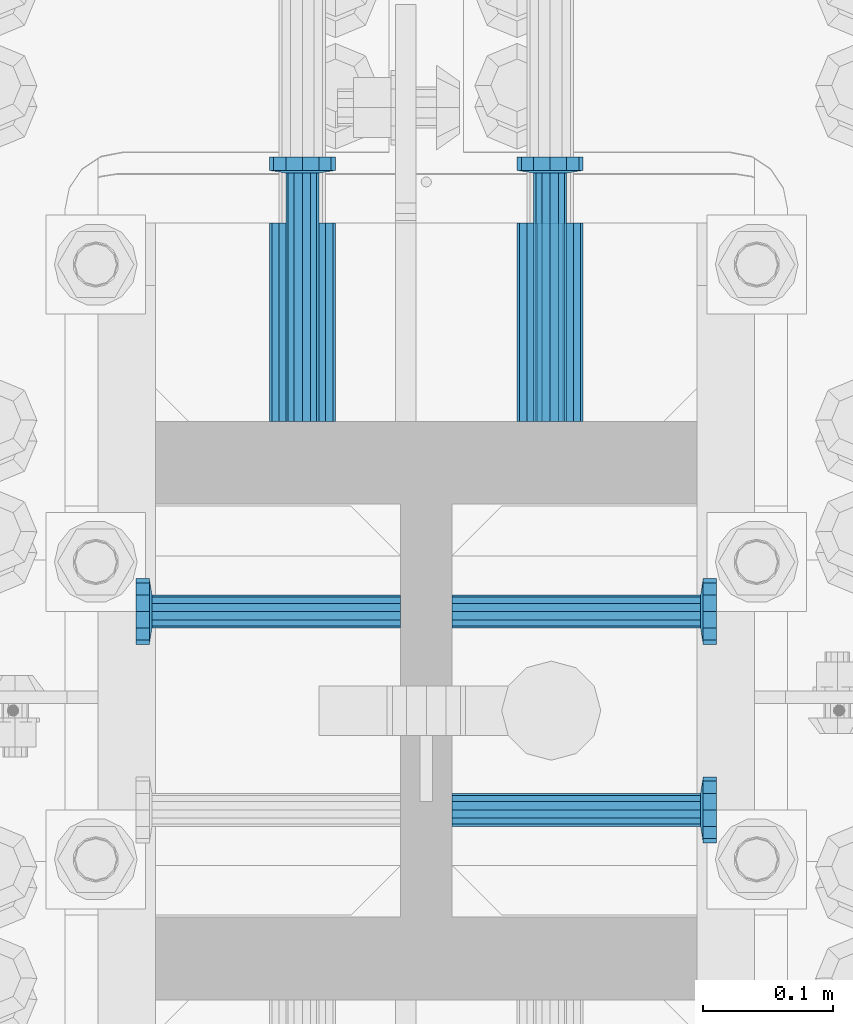
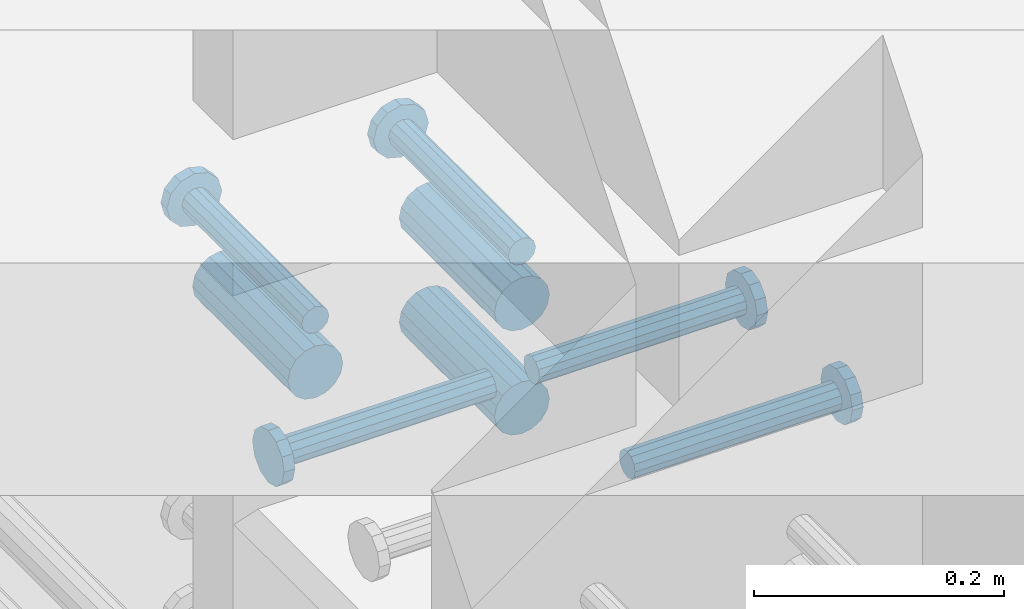
# One storey, part 1304 of 1763: 8 beams, 1 element without a shape of its own.
"""IFC2X3 building model written with IfcOpenShell, lengths in millimetres."""

import ifcopenshell
import ifcopenshell.guid

model = None  # the IFC model being written
_history = None  # IfcOwnerHistory: only IFC2X3 demands one
_inside = {}  # id of a spatial element -> (the spatial element, [elements in it])
_under = {}  # id of a project, library or spatial element -> (it, [spatial elements below it])
_declared = {}  # id of a project -> (the project, [libraries it declares])
_typed = {}  # id of a type object -> (the type object, [elements of that type])
_made_of = {}  # id of a material, layer set ... -> (it, [elements and type objects made of it])


def new_model(schema):
    """Start an empty IFC model of exactly this schema.

    Asked for "IFC4X3", IfcOpenShell would pick the latest addendum, in which some entities
    have other attributes; the version numbers below select the first issue.
    IFC2X3 requires an IfcOwnerHistory on every rooted entity: one is made here for all.
    """
    global model, _history
    if schema == "IFC4X3":
        model = ifcopenshell.file(schema_version=(4, 3, 0, 0))
    else:
        model = ifcopenshell.file(schema=schema)
    _inside.clear()
    _under.clear()
    _declared.clear()
    _typed.clear()
    _made_of.clear()
    _history = None
    if model.schema == "IFC2X3":
        org = make("IfcOrganization", Name="unknown")
        user = make(
            "IfcPersonAndOrganization",
            ThePerson=make("IfcPerson", FamilyName="unknown"),
            TheOrganization=org,
        )
        app = make(
            "IfcApplication",
            ApplicationDeveloper=org,
            Version="unknown",
            ApplicationFullName="unknown",
            ApplicationIdentifier="unknown",
        )
        _history = make(
            "IfcOwnerHistory",
            OwningUser=user,
            OwningApplication=app,
            ChangeAction="ADDED",
            CreationDate=0,
        )
    return model


def make(cls, **values):
    """One entity of the class cls with the attributes given. An attribute that is None is left unset."""
    return model.create_entity(
        cls, **{name: value for name, value in values.items() if value is not None}
    )


def rooted(cls, **values):
    """An entity with a GlobalId (a new one), such as an element, a storey or a relation."""
    return make(cls, GlobalId=ifcopenshell.guid.new(), OwnerHistory=_history, **values)


def si_unit(unit_type, name, prefix=None):
    """IfcSIUnit, for example si_unit("LENGTHUNIT", "METRE", prefix="MILLI")."""
    return make("IfcSIUnit", UnitType=unit_type, Prefix=prefix, Name=name)


def assignment(units):
    """IfcUnitAssignment: the units of a project."""
    return None if units is None else make("IfcUnitAssignment", Units=units)


def point(xyz):
    """IfcCartesianPoint."""
    return None if xyz is None else make("IfcCartesianPoint", Coordinates=xyz)


def direction(xyz):
    """IfcDirection."""
    return None if xyz is None else make("IfcDirection", DirectionRatios=xyz)


def frame(location, z_axis=None, x_axis=None):
    """IfcAxis2Placement3D, a coordinate frame: its origin and axes. An axis left out is left unset."""
    return make(
        "IfcAxis2Placement3D",
        Location=point(location),
        Axis=direction(z_axis),
        RefDirection=direction(x_axis),
    )


def origin_with_axes():
    """The frame at (0, 0, 0) with the z axis (0, 0, 1) and the x axis (1, 0, 0) written out."""
    return frame((0.0, 0.0, 0.0), z_axis=(0.0, 0.0, 1.0), x_axis=(1.0, 0.0, 0.0))


def place(relative_to, where):
    """IfcLocalPlacement: puts the frame where relative to a parent placement (None: the world)."""
    return make(
        "IfcLocalPlacement", PlacementRelTo=relative_to, RelativePlacement=where
    )


def context(
    kind, dimensions, precision=None, world=None, true_north=None, identifier=None
):
    """IfcGeometricRepresentationContext, for example the 3D "Model" context."""
    return make(
        "IfcGeometricRepresentationContext",
        ContextIdentifier=identifier,
        ContextType=kind,
        CoordinateSpaceDimension=dimensions,
        Precision=precision,
        WorldCoordinateSystem=world,
        TrueNorth=true_north,
    )


def subcontext(parent, identifier, kind, view, scale=None):
    """IfcGeometricRepresentationSubContext, for example "Body" below "Model"."""
    return make(
        "IfcGeometricRepresentationSubContext",
        ContextIdentifier=identifier,
        ContextType=kind,
        ParentContext=parent,
        TargetScale=scale,
        TargetView=view,
    )


def project(units=None, contexts=None):
    """IfcProject with its units and contexts."""
    return rooted(
        "IfcProject",
        Name="project",
        RepresentationContexts=contexts,
        UnitsInContext=assignment(units),
    )


def spatial(cls, under=None, at=None, **own):
    """A site, building, storey or space (cls), placed at a placement, below another one or the project."""
    s = rooted(cls, ObjectPlacement=at, **own)
    if under is not None:
        _under.setdefault(under.id(), (under, []))[1].append(s)
    return s


def faces_of(points, faces, orient=None, outer=None):
    """IfcFace entities. A face is a list of loops; a loop is a list of indices into points, from 0.

    orient and outer hold one flag for each loop. By default every Orientation is true, the
    first loop of a face is its IfcFaceOuterBound and the others are IfcFaceBound.
    """
    made = []
    for i, loops in enumerate(faces):
        bounds = []
        for j, loop in enumerate(loops):
            is_outer = j == 0 if outer is None else outer[i][j]
            bounds.append(
                make(
                    "IfcFaceOuterBound" if is_outer else "IfcFaceBound",
                    Bound=make("IfcPolyLoop", Polygon=[points[k] for k in loop]),
                    Orientation=True if orient is None else orient[i][j],
                )
            )
        made.append(make("IfcFace", Bounds=bounds))
    return made


def faceted_brep(points, faces, orient=None, outer=None, voids=None):
    """IfcFacetedBrep: a solid bounded by flat faces; with voids (closed shells), ...WithVoids."""
    shared = [point(p) for p in points]
    hull = make("IfcClosedShell", CfsFaces=faces_of(shared, faces, orient, outer))
    if voids is None:
        return make("IfcFacetedBrep", Outer=hull)
    return make(
        "IfcFacetedBrepWithVoids",
        Outer=hull,
        Voids=[
            make(cls, CfsFaces=faces_of(shared, fs, o, b)) for cls, fs, o, b in voids
        ],
    )


def shape(context_of_items, identifier, shape_type, items):
    """IfcShapeRepresentation: the items that make up one representation, for example the "Body"."""
    return make(
        "IfcShapeRepresentation",
        ContextOfItems=context_of_items,
        RepresentationIdentifier=identifier,
        RepresentationType=shape_type,
        Items=items,
    )


def material(Name=None, Category=None):
    """IfcMaterial."""
    return make("IfcMaterial", Name=Name, Category=Category)


def made_of(thing, what):
    """Note that an element or type object is made of a material, layer set ...; save() writes the relation."""
    if what is not None:
        _made_of.setdefault(what.id(), (what, []))[1].append(thing)
    return thing


def type_object(cls, material=None, **own):
    """A type object (cls), such as IfcWallType, which elements share."""
    return made_of(rooted(cls, **own), material)


def element(
    cls,
    number,
    at=None,
    inside=None,
    cuts=None,
    type_object=None,
    material=None,
    context=None,
    identifier="Body",
    shape_type=None,
    held_by="IfcProductDefinitionShape",
    body=None,
    shapes=None,
    **own,
):
    """One element of the class cls, such as IfcWall. Its Tag is "e" and its number.

    at: its placement. inside: the storey or other place that contains it. cuts: it is an
    opening in that element (IfcRelVoidsElement). A single representation is given by context,
    identifier, shape_type and body (its items); several are given by shapes. held_by: the class
    of the entity that holds the representations. save() writes the other relations.
    """
    e = rooted(cls, Tag="e%d" % number, ObjectPlacement=at, **own)
    if body is not None:
        shapes = [shape(context, identifier, shape_type, body)]
    if shapes is not None:
        e.Representation = make(held_by, Representations=shapes)
    if inside is not None:
        _inside.setdefault(inside.id(), (inside, []))[1].append(e)
    if cuts is not None:
        rooted(
            "IfcRelVoidsElement", RelatingBuildingElement=cuts, RelatedOpeningElement=e
        )
    if type_object is not None:
        _typed.setdefault(type_object.id(), (type_object, []))[1].append(e)
    return made_of(e, material)


def aggregate(whole, parts):
    """IfcRelAggregates: a whole, such as a stair, and the parts it consists of."""
    return rooted("IfcRelAggregates", RelatingObject=whole, RelatedObjects=parts)


def save(model, path):
    """Write the relations noted so far, then the file.

    IfcRelAggregates (storeys below a building ...), IfcRelContainedInSpatialStructure (elements
    in a storey), IfcRelDefinesByType, IfcRelAssociatesMaterial and IfcRelDeclares: one each for
    every whole, place, type object, material and project.
    """
    for whole, parts in _under.values():
        aggregate(whole, parts)
    for where, things in _inside.values():
        rooted(
            "IfcRelContainedInSpatialStructure",
            RelatedElements=things,
            RelatingStructure=where,
        )
    for kind, things in _typed.values():
        rooted("IfcRelDefinesByType", RelatedObjects=things, RelatingType=kind)
    for what, things in _made_of.values():
        rooted("IfcRelAssociatesMaterial", RelatedObjects=things, RelatingMaterial=what)
    for by, libraries in _declared.values():
        rooted("IfcRelDeclares", RelatingContext=by, RelatedDefinitions=libraries)
    model.write(path)


model = new_model("IFC2X3")

# Units and contexts
model_context = context("Model", 3, precision=1e-05, world=origin_with_axes())
body_context = subcontext(model_context, "Body", "Model", "MODEL_VIEW")
ifc_project = project(units=[si_unit("LENGTHUNIT", "METRE", prefix="MILLI"), si_unit("AREAUNIT", "SQUARE_METRE"), si_unit("VOLUMEUNIT", "CUBIC_METRE"), si_unit("MASSUNIT", "GRAM", prefix="KILO"), si_unit("TIMEUNIT", "SECOND"), si_unit("PLANEANGLEUNIT", "RADIAN"), si_unit("SOLIDANGLEUNIT", "STERADIAN"), si_unit("THERMODYNAMICTEMPERATUREUNIT", "DEGREE_CELSIUS"), si_unit("LUMINOUSINTENSITYUNIT", "LUMEN")], contexts=[model_context])

# Site, building, storey
site_placement = place(None, origin_with_axes())
site = spatial("IfcSite", under=ifc_project, at=site_placement, CompositionType="ELEMENT")
building_placement = place(site_placement, origin_with_axes())
building = spatial("IfcBuilding", under=site, at=building_placement, Name="Undefined", CompositionType="ELEMENT")
storey_placement = place(building_placement, origin_with_axes())
storey = spatial("IfcBuildingStorey", under=building, at=storey_placement, Name="Undefined", CompositionType="ELEMENT", Elevation=0.0)

# Assembly, beams
assembly_placement = place(storey_placement, origin_with_axes())
assembly = element("IfcElementAssembly", 1, at=assembly_placement, inside=storey, Name="COLUMN", AssemblyPlace="NOTDEFINED", PredefinedType="RIGID_FRAME")
ifc_material_1 = material(Name="STEEL/A706-GR.80")
beam_type_1 = type_object("IfcBeamType", PredefinedType="NOTDEFINED")
beam_1_placement = place(assembly_placement, frame((-23932.5872736985, 679.449862528949, 4775.20000000009), z_axis=(0.0, 0.0, 1.0), x_axis=(0.0, 1.0, 0.0)))
beam_1 = element("IfcBeam", 2, at=beam_1_placement, type_object=beam_type_1, material=ifc_material_1, Name="HALF COUPLER F", context=body_context, shape_type="Brep", body=[
    faceted_brep([(32.7659999999996, -8.95349999999962, -15.507916905568), (32.7659999999996, 0.0, -17.9070000000002), (32.7659999999996, 8.95349999999962, -15.507916905568), (32.7659999999996, 15.507916905568, -8.95350000000008), (32.7659999999996, 17.9069999999992, 0.0), (32.7659999999996, 15.507916905568, 8.95350000000008), (32.7659999999996, 8.95349999999962, 15.507916905568), (32.7659999999996, 0.0, 17.9070000000002), (32.7659999999996, -8.95349999999962, 15.507916905568), (32.7659999999996, -15.507916905568, 8.95350000000008), (32.7659999999996, -17.9069999999992, 0.0), (32.7659999999996, -15.507916905568, -8.95350000000008), (152.400103102711, -15.507916905568, 8.95350000000008), (152.400103102711, -8.95349999999962, 15.507916905568), (152.400103102711, -17.9069999999992, 0.0), (152.400103102711, -15.507916905568, -8.95350000000008), (152.400103102711, -8.95349999999962, -15.507916905568), (152.400103102711, 0.0, -17.9070000000002), (152.400103102711, 8.95349999999962, -15.507916905568), (152.400103102711, 15.507916905568, -8.95350000000008), (152.400103102711, 17.9069999999992, 0.0), (152.400103102711, 15.507916905568, 8.95350000000008), (152.400103102711, 8.95349999999962, 15.507916905568), (152.400103102711, 0.0, 17.9070000000002), (0.0, -23.466540125788, 9.72015918207308), (0.0, -17.9605122421381, 17.9605122421385), (0.0, -9.72015918207398, 23.4665401257867), (0.0, 0.0, 25.4000000000001), (0.0, 9.72015918207398, 23.4665401257867), (0.0, 17.9605122421381, 17.9605122421385), (0.0, 23.466540125788, 9.72015918207308), (0.0, 25.4000000000015, 0.0), (0.0, 23.466540125788, -9.72015918207308), (0.0, 17.9605122421381, -17.9605122421385), (0.0, 9.72015918207398, -23.4665401257867), (0.0, 0.0, -25.4000000000001), (0.0, -9.72015918207398, -23.4665401257867), (0.0, -17.9605122421381, -17.9605122421385), (0.0, -23.466540125788, -9.72015918207308), (0.0, -25.4000000000015, 0.0), (152.400103102711, -25.4000000000015, 0.0), (152.400103102711, -23.466540125788, 9.72015918207308), (152.400103102711, -17.9605122421381, 17.9605122421385), (152.400103102711, -9.72015918207398, 23.4665401257867), (152.400103102711, 0.0, 25.4000000000001), (152.400103102711, 9.72015918207398, 23.4665401257867), (152.400103102711, 17.9605122421381, 17.9605122421385), (152.400103102711, 23.466540125788, 9.72015918207308), (152.400103102711, 25.4000000000015, 0.0), (152.400103102711, 23.466540125788, -9.72015918207308), (152.400103102711, 17.9605122421381, -17.9605122421385), (152.400103102711, 9.72015918207398, -23.4665401257867), (152.400103102711, 0.0, -25.4000000000001), (152.400103102711, -9.72015918207398, -23.4665401257867), (152.400103102711, -17.9605122421381, -17.9605122421385), (152.400103102711, -23.466540125788, -9.72015918207308)], [[[0, 1, 2, 3, 4, 5, 6, 7, 8, 9, 10, 11]], [[12, 9, 8, 13]], [[14, 10, 9, 12]], [[15, 11, 10, 14]], [[16, 0, 11, 15]], [[17, 1, 0, 16]], [[18, 2, 1, 17]], [[19, 3, 2, 18]], [[20, 4, 3, 19]], [[21, 5, 4, 20]], [[22, 6, 5, 21]], [[23, 7, 6, 22]], [[13, 8, 7, 23]], [[24, 25, 26, 27, 28, 29, 30, 31, 32, 33, 34, 35, 36, 37, 38, 39]], [[24, 39, 40, 41]], [[25, 24, 41, 42]], [[26, 25, 42, 43]], [[27, 26, 43, 44]], [[28, 27, 44, 45]], [[29, 28, 45, 46]], [[30, 29, 46, 47]], [[31, 30, 47, 48]], [[32, 31, 48, 49]], [[33, 32, 49, 50]], [[34, 33, 50, 51]], [[35, 34, 51, 52]], [[36, 35, 52, 53]], [[37, 36, 53, 54]], [[38, 37, 54, 55]], [[39, 38, 55, 40]], [[54, 53, 52, 51, 50, 49, 48, 47, 46, 45, 44, 43, 42, 41, 40, 55], [21, 20, 19, 18, 17, 16, 15, 14, 12, 13, 23, 22]]]),
])
beam_2_placement = place(assembly_placement, frame((-24123.0872736984, 679.450068735522, 4876.80000000009), z_axis=(0.0, 0.0, 1.0), x_axis=(0.0, 1.0, 0.0)))
beam_2 = element("IfcBeam", 3, at=beam_2_placement, type_object=beam_type_1, material=ifc_material_1, Name="HALF COUPLER F", context=body_context, shape_type="Brep", body=[
    faceted_brep([(32.7659999999996, -8.95349999999962, -15.507916905568), (32.7659999999996, 0.0, -17.9070000000002), (32.7659999999996, 8.95349999999962, -15.507916905568), (32.7659999999996, 15.507916905568, -8.95350000000008), (32.7659999999996, 17.9069999999992, 0.0), (32.7659999999996, 15.507916905568, 8.95350000000008), (32.7659999999996, 8.95349999999962, 15.507916905568), (32.7659999999996, 0.0, 17.9070000000002), (32.7659999999996, -8.95349999999962, 15.507916905568), (32.7659999999996, -15.507916905568, 8.95350000000008), (32.7659999999996, -17.9069999999992, 0.0), (32.7659999999996, -15.507916905568, -8.95350000000008), (152.400103102711, -15.507916905568, 8.95350000000008), (152.400103102711, -8.95349999999962, 15.507916905568), (152.400103102711, -17.9069999999992, 0.0), (152.400103102711, -15.507916905568, -8.95350000000008), (152.400103102711, -8.95349999999962, -15.507916905568), (152.400103102711, 0.0, -17.9070000000002), (152.400103102711, 8.95349999999962, -15.507916905568), (152.400103102711, 15.507916905568, -8.95350000000008), (152.400103102711, 17.9069999999992, 0.0), (152.400103102711, 15.507916905568, 8.95350000000008), (152.400103102711, 8.95349999999962, 15.507916905568), (152.400103102711, 0.0, 17.9070000000002), (0.0, -23.466540125788, 9.72015918207308), (0.0, -17.9605122421381, 17.9605122421385), (0.0, -9.72015918207398, 23.4665401257867), (0.0, 0.0, 25.4000000000001), (0.0, 9.72015918207398, 23.4665401257867), (0.0, 17.9605122421381, 17.9605122421385), (0.0, 23.466540125788, 9.72015918207308), (0.0, 25.4000000000015, 0.0), (0.0, 23.466540125788, -9.72015918207308), (0.0, 17.9605122421381, -17.9605122421385), (0.0, 9.72015918207398, -23.4665401257867), (0.0, 0.0, -25.4000000000001), (0.0, -9.72015918207398, -23.4665401257867), (0.0, -17.9605122421381, -17.9605122421385), (0.0, -23.466540125788, -9.72015918207308), (0.0, -25.4000000000015, 0.0), (152.400103102711, -25.4000000000015, 0.0), (152.400103102711, -23.466540125788, 9.72015918207308), (152.400103102711, -17.9605122421381, 17.9605122421385), (152.400103102711, -9.72015918207398, 23.4665401257867), (152.400103102711, 0.0, 25.4000000000001), (152.400103102711, 9.72015918207398, 23.4665401257867), (152.400103102711, 17.9605122421381, 17.9605122421385), (152.400103102711, 23.466540125788, 9.72015918207308), (152.400103102711, 25.4000000000015, 0.0), (152.400103102711, 23.466540125788, -9.72015918207308), (152.400103102711, 17.9605122421381, -17.9605122421385), (152.400103102711, 9.72015918207398, -23.4665401257867), (152.400103102711, 0.0, -25.4000000000001), (152.400103102711, -9.72015918207398, -23.4665401257867), (152.400103102711, -17.9605122421381, -17.9605122421385), (152.400103102711, -23.466540125788, -9.72015918207308)], [[[0, 1, 2, 3, 4, 5, 6, 7, 8, 9, 10, 11]], [[12, 9, 8, 13]], [[14, 10, 9, 12]], [[15, 11, 10, 14]], [[16, 0, 11, 15]], [[17, 1, 0, 16]], [[18, 2, 1, 17]], [[19, 3, 2, 18]], [[20, 4, 3, 19]], [[21, 5, 4, 20]], [[22, 6, 5, 21]], [[23, 7, 6, 22]], [[13, 8, 7, 23]], [[24, 25, 26, 27, 28, 29, 30, 31, 32, 33, 34, 35, 36, 37, 38, 39]], [[24, 39, 40, 41]], [[25, 24, 41, 42]], [[26, 25, 42, 43]], [[27, 26, 43, 44]], [[28, 27, 44, 45]], [[29, 28, 45, 46]], [[30, 29, 46, 47]], [[31, 30, 47, 48]], [[32, 31, 48, 49]], [[33, 32, 49, 50]], [[34, 33, 50, 51]], [[35, 34, 51, 52]], [[36, 35, 52, 53]], [[37, 36, 53, 54]], [[38, 37, 54, 55]], [[39, 38, 55, 40]], [[54, 53, 52, 51, 50, 49, 48, 47, 46, 45, 44, 43, 42, 41, 40, 55], [21, 20, 19, 18, 17, 16, 15, 14, 12, 13, 23, 22]]]),
])
beam_3_placement = place(assembly_placement, frame((-23932.5872736985, 679.449999999998, 4876.80000000009), z_axis=(0.0, 0.0, 1.0), x_axis=(0.0, 1.0, 0.0)))
beam_3 = element("IfcBeam", 4, at=beam_3_placement, type_object=beam_type_1, material=ifc_material_1, Name="HALF COUPLER F", context=body_context, shape_type="Brep", body=[
    faceted_brep([(32.7659999999996, -8.95349999999962, -15.507916905568), (32.7659999999996, 0.0, -17.9070000000002), (32.7659999999996, 8.95349999999962, -15.507916905568), (32.7659999999996, 15.507916905568, -8.95350000000008), (32.7659999999996, 17.9069999999992, 0.0), (32.7659999999996, 15.507916905568, 8.95350000000008), (32.7659999999996, 8.95349999999962, 15.507916905568), (32.7659999999996, 0.0, 17.9070000000002), (32.7659999999996, -8.95349999999962, 15.507916905568), (32.7659999999996, -15.507916905568, 8.95350000000008), (32.7659999999996, -17.9069999999992, 0.0), (32.7659999999996, -15.507916905568, -8.95350000000008), (152.400103102711, -15.507916905568, 8.95350000000008), (152.400103102711, -8.95349999999962, 15.507916905568), (152.400103102711, -17.9069999999992, 0.0), (152.400103102711, -15.507916905568, -8.95350000000008), (152.400103102711, -8.95349999999962, -15.507916905568), (152.400103102711, 0.0, -17.9070000000002), (152.400103102711, 8.95349999999962, -15.507916905568), (152.400103102711, 15.507916905568, -8.95350000000008), (152.400103102711, 17.9069999999992, 0.0), (152.400103102711, 15.507916905568, 8.95350000000008), (152.400103102711, 8.95349999999962, 15.507916905568), (152.400103102711, 0.0, 17.9070000000002), (0.0, -23.466540125788, 9.72015918207308), (0.0, -17.9605122421381, 17.9605122421385), (0.0, -9.72015918207398, 23.4665401257867), (0.0, 0.0, 25.4000000000001), (0.0, 9.72015918207398, 23.4665401257867), (0.0, 17.9605122421381, 17.9605122421385), (0.0, 23.466540125788, 9.72015918207308), (0.0, 25.4000000000015, 0.0), (0.0, 23.466540125788, -9.72015918207308), (0.0, 17.9605122421381, -17.9605122421385), (0.0, 9.72015918207398, -23.4665401257867), (0.0, 0.0, -25.4000000000001), (0.0, -9.72015918207398, -23.4665401257867), (0.0, -17.9605122421381, -17.9605122421385), (0.0, -23.466540125788, -9.72015918207308), (0.0, -25.4000000000015, 0.0), (152.400103102711, -25.4000000000015, 0.0), (152.400103102711, -23.466540125788, 9.72015918207308), (152.400103102711, -17.9605122421381, 17.9605122421385), (152.400103102711, -9.72015918207398, 23.4665401257867), (152.400103102711, 0.0, 25.4000000000001), (152.400103102711, 9.72015918207398, 23.4665401257867), (152.400103102711, 17.9605122421381, 17.9605122421385), (152.400103102711, 23.466540125788, 9.72015918207308), (152.400103102711, 25.4000000000015, 0.0), (152.400103102711, 23.466540125788, -9.72015918207308), (152.400103102711, 17.9605122421381, -17.9605122421385), (152.400103102711, 9.72015918207398, -23.4665401257867), (152.400103102711, 0.0, -25.4000000000001), (152.400103102711, -9.72015918207398, -23.4665401257867), (152.400103102711, -17.9605122421381, -17.9605122421385), (152.400103102711, -23.466540125788, -9.72015918207308)], [[[0, 1, 2, 3, 4, 5, 6, 7, 8, 9, 10, 11]], [[12, 9, 8, 13]], [[14, 10, 9, 12]], [[15, 11, 10, 14]], [[16, 0, 11, 15]], [[17, 1, 0, 16]], [[18, 2, 1, 17]], [[19, 3, 2, 18]], [[20, 4, 3, 19]], [[21, 5, 4, 20]], [[22, 6, 5, 21]], [[23, 7, 6, 22]], [[13, 8, 7, 23]], [[24, 25, 26, 27, 28, 29, 30, 31, 32, 33, 34, 35, 36, 37, 38, 39]], [[24, 39, 40, 41]], [[25, 24, 41, 42]], [[26, 25, 42, 43]], [[27, 26, 43, 44]], [[28, 27, 44, 45]], [[29, 28, 45, 46]], [[30, 29, 46, 47]], [[31, 30, 47, 48]], [[32, 31, 48, 49]], [[33, 32, 49, 50]], [[34, 33, 50, 51]], [[35, 34, 51, 52]], [[36, 35, 52, 53]], [[37, 36, 53, 54]], [[38, 37, 54, 55]], [[39, 38, 55, 40]], [[54, 53, 52, 51, 50, 49, 48, 47, 46, 45, 44, 43, 42, 41, 40, 55], [21, 20, 19, 18, 17, 16, 15, 14, 12, 13, 23, 22]]]),
])
ifc_material_2 = material(Name="STEEL/A108")
beam_type_2 = type_object("IfcBeamType", PredefinedType="NOTDEFINED")
beam_4_placement = place(assembly_placement, frame((-24007.9935227012, 381.000138137178, 4927.60000000008), z_axis=(0.0, -1.0, 0.0), x_axis=(1.0, 0.0, 0.0)))
beam_4 = element("IfcBeam", 5, at=beam_4_placement, type_object=beam_type_2, material=ifc_material_2, Name="HEADED STUD ANCHOR", context=body_context, shape_type="Brep", body=[
    faceted_brep([(0.0, -12.6999999999971, -1.81898940354586e-12), (3.63797880709171e-12, -11.0, -6.34999990463257), (191.00799999576, -11.0, -6.34999990454889), (191.007999995752, -12.6999998092651, 8.36735125631094e-11), (7.27595761418343e-12, -6.34999990463257, -11.0), (191.00799999576, -6.34999990463257, -10.9999999999163), (3.63797880709171e-12, 0.0, -12.6999998092651), (191.00799999576, 0.0, -12.6999998091815), (7.27595761418343e-12, 6.34999990463257, -11.0), (191.00799999576, 6.34999990463257, -10.9999999999163), (3.63797880709171e-12, 11.0, -6.34999990463257), (191.00799999576, 11.0, -6.34999990454889), (0.0, 12.6999999999971, -1.81898940354586e-12), (191.007999995752, 12.6999998092651, 8.36735125631094e-11), (0.0, 11.0, 6.34999990463257), (191.007999995752, 11.0, 6.34999990471624), (-3.63797880709171e-12, 6.34999990463257, 11.0), (191.007999995749, 6.34999990463257, 11.0000000000837), (-3.63797880709171e-12, 0.0, 12.6999998092651), (191.007999995749, 0.0, 12.6999998093488), (-3.63797880709171e-12, -6.34999990463257, 11.0), (191.007999995749, -6.34999990463257, 11.0000000000837), (0.0, -11.0, 6.34999990463257), (191.007999995752, -11.0, 6.34999990471624), (193.039999995715, -22.0, -12.6999998091796), (193.039999995708, -25.3999996185303, 8.54925019666553e-11), (193.039999995719, -12.6999998092651, -21.9999999999145), (193.039999995719, 0.0, -25.3999996184448), (193.039999995719, 12.6999998092651, -21.9999999999145), (193.039999995715, 22.0, -12.6999998091796), (193.039999995708, 25.3999996185303, 8.54925019666553e-11), (193.039999995704, 22.0, 12.6999998093506), (193.039999995701, 12.6999998092651, 22.0000000000855), (193.039999995697, 0.0, 25.3999996186158), (193.039999995701, -12.6999998092651, 22.0000000000855), (193.039999995704, -22.0, 12.6999998093506), (203.199999995486, -22.0, -12.6999998091742), (203.199999995482, -25.3999996185303, 9.09494701772928e-11), (203.199999995493, -12.6999998092651, -21.9999999999091), (203.199999995493, 0.0, -25.3999996184393), (203.199999995493, 12.6999998092651, -21.9999999999091), (203.199999995486, 22.0, -12.6999998091742), (203.199999995482, 25.3999996185303, 9.09494701772928e-11), (203.199999995479, 22.0, 12.6999998093561), (203.199999995475, 12.6999998092651, 22.0000000000909), (203.199999995471, 0.0, 25.3999996186212), (203.199999995475, -12.6999998092651, 22.0000000000909), (203.199999995479, -22.0, 12.6999998093561)], [[[0, 1, 2, 3]], [[1, 4, 5, 2]], [[4, 6, 7, 5]], [[6, 8, 9, 7]], [[8, 10, 11, 9]], [[10, 12, 13, 11]], [[12, 14, 15, 13]], [[14, 16, 17, 15]], [[16, 18, 19, 17]], [[18, 20, 21, 19]], [[20, 22, 23, 21]], [[22, 0, 3, 23]], [[22, 20, 18, 16, 14, 12, 10, 8, 6, 4, 1, 0]], [[3, 2, 24, 25]], [[2, 5, 26, 24]], [[5, 7, 27, 26]], [[7, 9, 28, 27]], [[9, 11, 29, 28]], [[11, 13, 30, 29]], [[13, 15, 31, 30]], [[15, 17, 32, 31]], [[17, 19, 33, 32]], [[19, 21, 34, 33]], [[21, 23, 35, 34]], [[23, 3, 25, 35]], [[25, 24, 36, 37]], [[24, 26, 38, 36]], [[26, 27, 39, 38]], [[27, 28, 40, 39]], [[28, 29, 41, 40]], [[29, 30, 42, 41]], [[30, 31, 43, 42]], [[31, 32, 44, 43]], [[32, 33, 45, 44]], [[33, 34, 46, 45]], [[34, 35, 47, 46]], [[35, 25, 37, 47]], [[38, 39, 40, 41, 42, 43, 44, 45, 46, 47, 37, 36]]]),
])
beam_5_placement = place(assembly_placement, frame((-24007.9935236984, 533.400138136968, 4927.60000000008), z_axis=(0.0, -1.0, 0.0), x_axis=(1.0, 0.0, 0.0)))
beam_5 = element("IfcBeam", 6, at=beam_5_placement, type_object=beam_type_2, material=ifc_material_2, Name="HEADED STUD ANCHOR", context=body_context, shape_type="Brep", body=[
    faceted_brep([(0.0, -12.6999999999971, -1.81898940354586e-12), (3.63797880709171e-12, -11.0, -6.34999990463257), (191.00799999576, -11.0, -6.34999990454889), (191.007999995752, -12.6999998092651, 8.36735125631094e-11), (7.27595761418343e-12, -6.34999990463257, -11.0), (191.00799999576, -6.34999990463257, -10.9999999999163), (3.63797880709171e-12, 0.0, -12.6999998092651), (191.00799999576, 0.0, -12.6999998091815), (7.27595761418343e-12, 6.34999990463257, -11.0), (191.00799999576, 6.34999990463257, -10.9999999999163), (3.63797880709171e-12, 11.0, -6.34999990463257), (191.00799999576, 11.0, -6.34999990454889), (0.0, 12.6999999999971, -1.81898940354586e-12), (191.007999995752, 12.6999998092651, 8.36735125631094e-11), (0.0, 11.0, 6.34999990463257), (191.007999995752, 11.0, 6.34999990471624), (-3.63797880709171e-12, 6.34999990463257, 11.0), (191.007999995749, 6.34999990463257, 11.0000000000837), (-3.63797880709171e-12, 0.0, 12.6999998092651), (191.007999995749, 0.0, 12.6999998093488), (-3.63797880709171e-12, -6.34999990463257, 11.0), (191.007999995749, -6.34999990463257, 11.0000000000837), (0.0, -11.0, 6.34999990463257), (191.007999995752, -11.0, 6.34999990471624), (193.039999995715, -22.0, -12.6999998091796), (193.039999995708, -25.3999996185303, 8.54925019666553e-11), (193.039999995719, -12.6999998092651, -21.9999999999145), (193.039999995719, 0.0, -25.3999996184448), (193.039999995719, 12.6999998092651, -21.9999999999145), (193.039999995715, 22.0, -12.6999998091796), (193.039999995708, 25.3999996185303, 8.54925019666553e-11), (193.039999995704, 22.0, 12.6999998093506), (193.039999995701, 12.6999998092651, 22.0000000000855), (193.039999995697, 0.0, 25.3999996186158), (193.039999995701, -12.6999998092651, 22.0000000000855), (193.039999995704, -22.0, 12.6999998093506), (203.199999995486, -22.0, -12.6999998091742), (203.199999995482, -25.3999996185303, 9.09494701772928e-11), (203.199999995493, -12.6999998092651, -21.9999999999091), (203.199999995493, 0.0, -25.3999996184393), (203.199999995493, 12.6999998092651, -21.9999999999091), (203.199999995486, 22.0, -12.6999998091742), (203.199999995482, 25.3999996185303, 9.09494701772928e-11), (203.199999995479, 22.0, 12.6999998093561), (203.199999995475, 12.6999998092651, 22.0000000000909), (203.199999995471, 0.0, 25.3999996186212), (203.199999995475, -12.6999998092651, 22.0000000000909), (203.199999995479, -22.0, 12.6999998093561)], [[[0, 1, 2, 3]], [[1, 4, 5, 2]], [[4, 6, 7, 5]], [[6, 8, 9, 7]], [[8, 10, 11, 9]], [[10, 12, 13, 11]], [[12, 14, 15, 13]], [[14, 16, 17, 15]], [[16, 18, 19, 17]], [[18, 20, 21, 19]], [[20, 22, 23, 21]], [[22, 0, 3, 23]], [[22, 20, 18, 16, 14, 12, 10, 8, 6, 4, 1, 0]], [[3, 2, 24, 25]], [[2, 5, 26, 24]], [[5, 7, 27, 26]], [[7, 9, 28, 27]], [[9, 11, 29, 28]], [[11, 13, 30, 29]], [[13, 15, 31, 30]], [[15, 17, 32, 31]], [[17, 19, 33, 32]], [[19, 21, 34, 33]], [[21, 23, 35, 34]], [[23, 3, 25, 35]], [[25, 24, 36, 37]], [[24, 26, 38, 36]], [[26, 27, 39, 38]], [[27, 28, 40, 39]], [[28, 29, 41, 40]], [[29, 30, 42, 41]], [[30, 31, 43, 42]], [[31, 32, 44, 43]], [[32, 33, 45, 44]], [[33, 34, 46, 45]], [[34, 35, 47, 46]], [[35, 25, 37, 47]], [[38, 39, 40, 41, 42, 43, 44, 45, 46, 47, 37, 36]]]),
])
beam_6_placement = place(assembly_placement, frame((-23932.5872736985, 679.450068734938, 4927.60000000008), z_axis=(1.0, 0.0, 0.0), x_axis=(0.0, 1.0, 0.0)))
beam_6 = element("IfcBeam", 7, at=beam_6_placement, type_object=beam_type_2, material=ifc_material_2, Name="HEADED STUD ANCHOR", context=body_context, shape_type="Brep", body=[
    faceted_brep([(0.0, -12.6999999999971, -1.81898940354586e-12), (3.63797880709171e-12, -11.0, -6.34999990463257), (191.00799999576, -11.0, -6.34999990454889), (191.007999995752, -12.6999998092651, 8.36735125631094e-11), (7.27595761418343e-12, -6.34999990463257, -11.0), (191.00799999576, -6.34999990463257, -10.9999999999163), (3.63797880709171e-12, 0.0, -12.6999998092651), (191.00799999576, 0.0, -12.6999998091815), (7.27595761418343e-12, 6.34999990463257, -11.0), (191.00799999576, 6.34999990463257, -10.9999999999163), (3.63797880709171e-12, 11.0, -6.34999990463257), (191.00799999576, 11.0, -6.34999990454889), (0.0, 12.6999999999971, -1.81898940354586e-12), (191.007999995752, 12.6999998092651, 8.36735125631094e-11), (0.0, 11.0, 6.34999990463257), (191.007999995752, 11.0, 6.34999990471624), (-3.63797880709171e-12, 6.34999990463257, 11.0), (191.007999995749, 6.34999990463257, 11.0000000000837), (-3.63797880709171e-12, 0.0, 12.6999998092651), (191.007999995749, 0.0, 12.6999998093488), (-3.63797880709171e-12, -6.34999990463257, 11.0), (191.007999995749, -6.34999990463257, 11.0000000000837), (0.0, -11.0, 6.34999990463257), (191.007999995752, -11.0, 6.34999990471624), (193.039999995715, -22.0, -12.6999998091796), (193.039999995708, -25.3999996185303, 8.54925019666553e-11), (193.039999995719, -12.6999998092651, -21.9999999999145), (193.039999995719, 0.0, -25.3999996184448), (193.039999995719, 12.6999998092651, -21.9999999999145), (193.039999995715, 22.0, -12.6999998091796), (193.039999995708, 25.3999996185303, 8.54925019666553e-11), (193.039999995704, 22.0, 12.6999998093506), (193.039999995701, 12.6999998092651, 22.0000000000855), (193.039999995697, 0.0, 25.3999996186158), (193.039999995701, -12.6999998092651, 22.0000000000855), (193.039999995704, -22.0, 12.6999998093506), (203.199999995486, -22.0, -12.6999998091742), (203.199999995482, -25.3999996185303, 9.09494701772928e-11), (203.199999995493, -12.6999998092651, -21.9999999999091), (203.199999995493, 0.0, -25.3999996184393), (203.199999995493, 12.6999998092651, -21.9999999999091), (203.199999995486, 22.0, -12.6999998091742), (203.199999995482, 25.3999996185303, 9.09494701772928e-11), (203.199999995479, 22.0, 12.6999998093561), (203.199999995475, 12.6999998092651, 22.0000000000909), (203.199999995471, 0.0, 25.3999996186212), (203.199999995475, -12.6999998092651, 22.0000000000909), (203.199999995479, -22.0, 12.6999998093561)], [[[0, 1, 2, 3]], [[1, 4, 5, 2]], [[4, 6, 7, 5]], [[6, 8, 9, 7]], [[8, 10, 11, 9]], [[10, 12, 13, 11]], [[12, 14, 15, 13]], [[14, 16, 17, 15]], [[16, 18, 19, 17]], [[18, 20, 21, 19]], [[20, 22, 23, 21]], [[22, 0, 3, 23]], [[22, 20, 18, 16, 14, 12, 10, 8, 6, 4, 1, 0]], [[3, 2, 24, 25]], [[2, 5, 26, 24]], [[5, 7, 27, 26]], [[7, 9, 28, 27]], [[9, 11, 29, 28]], [[11, 13, 30, 29]], [[13, 15, 31, 30]], [[15, 17, 32, 31]], [[17, 19, 33, 32]], [[19, 21, 34, 33]], [[21, 23, 35, 34]], [[23, 3, 25, 35]], [[25, 24, 36, 37]], [[24, 26, 38, 36]], [[26, 27, 39, 38]], [[27, 28, 40, 39]], [[28, 29, 41, 40]], [[29, 30, 42, 41]], [[30, 31, 43, 42]], [[31, 32, 44, 43]], [[32, 33, 45, 44]], [[33, 34, 46, 45]], [[34, 35, 47, 46]], [[35, 25, 37, 47]], [[38, 39, 40, 41, 42, 43, 44, 45, 46, 47, 37, 36]]]),
])
beam_7_placement = place(assembly_placement, frame((-24123.0872736984, 679.450137470462, 4927.60000000008), z_axis=(1.0, 0.0, 0.0), x_axis=(0.0, 1.0, 0.0)))
beam_7 = element("IfcBeam", 8, at=beam_7_placement, type_object=beam_type_2, material=ifc_material_2, Name="HEADED STUD ANCHOR", context=body_context, shape_type="Brep", body=[
    faceted_brep([(0.0, -12.6999999999971, -1.81898940354586e-12), (3.63797880709171e-12, -11.0, -6.34999990463257), (191.00799999576, -11.0, -6.34999990454889), (191.007999995752, -12.6999998092651, 8.36735125631094e-11), (7.27595761418343e-12, -6.34999990463257, -11.0), (191.00799999576, -6.34999990463257, -10.9999999999163), (3.63797880709171e-12, 0.0, -12.6999998092651), (191.00799999576, 0.0, -12.6999998091815), (7.27595761418343e-12, 6.34999990463257, -11.0), (191.00799999576, 6.34999990463257, -10.9999999999163), (3.63797880709171e-12, 11.0, -6.34999990463257), (191.00799999576, 11.0, -6.34999990454889), (0.0, 12.6999999999971, -1.81898940354586e-12), (191.007999995752, 12.6999998092651, 8.36735125631094e-11), (0.0, 11.0, 6.34999990463257), (191.007999995752, 11.0, 6.34999990471624), (-3.63797880709171e-12, 6.34999990463257, 11.0), (191.007999995749, 6.34999990463257, 11.0000000000837), (-3.63797880709171e-12, 0.0, 12.6999998092651), (191.007999995749, 0.0, 12.6999998093488), (-3.63797880709171e-12, -6.34999990463257, 11.0), (191.007999995749, -6.34999990463257, 11.0000000000837), (0.0, -11.0, 6.34999990463257), (191.007999995752, -11.0, 6.34999990471624), (193.039999995715, -22.0, -12.6999998091796), (193.039999995708, -25.3999996185303, 8.54925019666553e-11), (193.039999995719, -12.6999998092651, -21.9999999999145), (193.039999995719, 0.0, -25.3999996184448), (193.039999995719, 12.6999998092651, -21.9999999999145), (193.039999995715, 22.0, -12.6999998091796), (193.039999995708, 25.3999996185303, 8.54925019666553e-11), (193.039999995704, 22.0, 12.6999998093506), (193.039999995701, 12.6999998092651, 22.0000000000855), (193.039999995697, 0.0, 25.3999996186158), (193.039999995701, -12.6999998092651, 22.0000000000855), (193.039999995704, -22.0, 12.6999998093506), (203.199999995486, -22.0, -12.6999998091742), (203.199999995482, -25.3999996185303, 9.09494701772928e-11), (203.199999995493, -12.6999998092651, -21.9999999999091), (203.199999995493, 0.0, -25.3999996184393), (203.199999995493, 12.6999998092651, -21.9999999999091), (203.199999995486, 22.0, -12.6999998091742), (203.199999995482, 25.3999996185303, 9.09494701772928e-11), (203.199999995479, 22.0, 12.6999998093561), (203.199999995475, 12.6999998092651, 22.0000000000909), (203.199999995471, 0.0, 25.3999996186212), (203.199999995475, -12.6999998092651, 22.0000000000909), (203.199999995479, -22.0, 12.6999998093561)], [[[0, 1, 2, 3]], [[1, 4, 5, 2]], [[4, 6, 7, 5]], [[6, 8, 9, 7]], [[8, 10, 11, 9]], [[10, 12, 13, 11]], [[12, 14, 15, 13]], [[14, 16, 17, 15]], [[16, 18, 19, 17]], [[18, 20, 21, 19]], [[20, 22, 23, 21]], [[22, 0, 3, 23]], [[22, 20, 18, 16, 14, 12, 10, 8, 6, 4, 1, 0]], [[3, 2, 24, 25]], [[2, 5, 26, 24]], [[5, 7, 27, 26]], [[7, 9, 28, 27]], [[9, 11, 29, 28]], [[11, 13, 30, 29]], [[13, 15, 31, 30]], [[15, 17, 32, 31]], [[17, 19, 33, 32]], [[19, 21, 34, 33]], [[21, 23, 35, 34]], [[23, 3, 25, 35]], [[25, 24, 36, 37]], [[24, 26, 38, 36]], [[26, 27, 39, 38]], [[27, 28, 40, 39]], [[28, 29, 41, 40]], [[29, 30, 42, 41]], [[30, 31, 43, 42]], [[31, 32, 44, 43]], [[32, 33, 45, 44]], [[33, 34, 46, 45]], [[34, 35, 47, 46]], [[35, 25, 37, 47]], [[38, 39, 40, 41, 42, 43, 44, 45, 46, 47, 37, 36]]]),
])
beam_8_placement = place(assembly_placement, frame((-24047.6810236984, 533.400137128455, 4927.60000000008), z_axis=(0.0, -1.0, 0.0), x_axis=(-1.0, 0.0, 0.0)))
beam_8 = element("IfcBeam", 9, at=beam_8_placement, type_object=beam_type_2, material=ifc_material_2, Name="HEADED STUD ANCHOR", context=body_context, shape_type="Brep", body=[
    faceted_brep([(0.0, -12.6999999999971, -1.81898940354586e-12), (3.63797880709171e-12, -11.0, -6.34999990463257), (191.00799999576, -11.0, -6.34999990454889), (191.007999995752, -12.6999998092651, 8.36735125631094e-11), (7.27595761418343e-12, -6.34999990463257, -11.0), (191.00799999576, -6.34999990463257, -10.9999999999163), (3.63797880709171e-12, 0.0, -12.6999998092651), (191.00799999576, 0.0, -12.6999998091815), (7.27595761418343e-12, 6.34999990463257, -11.0), (191.00799999576, 6.34999990463257, -10.9999999999163), (3.63797880709171e-12, 11.0, -6.34999990463257), (191.00799999576, 11.0, -6.34999990454889), (0.0, 12.6999999999971, -1.81898940354586e-12), (191.007999995752, 12.6999998092651, 8.36735125631094e-11), (0.0, 11.0, 6.34999990463257), (191.007999995752, 11.0, 6.34999990471624), (-3.63797880709171e-12, 6.34999990463257, 11.0), (191.007999995749, 6.34999990463257, 11.0000000000837), (-3.63797880709171e-12, 0.0, 12.6999998092651), (191.007999995749, 0.0, 12.6999998093488), (-3.63797880709171e-12, -6.34999990463257, 11.0), (191.007999995749, -6.34999990463257, 11.0000000000837), (0.0, -11.0, 6.34999990463257), (191.007999995752, -11.0, 6.34999990471624), (193.039999995715, -22.0, -12.6999998091796), (193.039999995708, -25.3999996185303, 8.54925019666553e-11), (193.039999995719, -12.6999998092651, -21.9999999999145), (193.039999995719, 0.0, -25.3999996184448), (193.039999995719, 12.6999998092651, -21.9999999999145), (193.039999995715, 22.0, -12.6999998091796), (193.039999995708, 25.3999996185303, 8.54925019666553e-11), (193.039999995704, 22.0, 12.6999998093506), (193.039999995701, 12.6999998092651, 22.0000000000855), (193.039999995697, 0.0, 25.3999996186158), (193.039999995701, -12.6999998092651, 22.0000000000855), (193.039999995704, -22.0, 12.6999998093506), (203.199999995486, -22.0, -12.6999998091742), (203.199999995482, -25.3999996185303, 9.09494701772928e-11), (203.199999995493, -12.6999998092651, -21.9999999999091), (203.199999995493, 0.0, -25.3999996184393), (203.199999995493, 12.6999998092651, -21.9999999999091), (203.199999995486, 22.0, -12.6999998091742), (203.199999995482, 25.3999996185303, 9.09494701772928e-11), (203.199999995479, 22.0, 12.6999998093561), (203.199999995475, 12.6999998092651, 22.0000000000909), (203.199999995471, 0.0, 25.3999996186212), (203.199999995475, -12.6999998092651, 22.0000000000909), (203.199999995479, -22.0, 12.6999998093561)], [[[0, 1, 2, 3]], [[1, 4, 5, 2]], [[4, 6, 7, 5]], [[6, 8, 9, 7]], [[8, 10, 11, 9]], [[10, 12, 13, 11]], [[12, 14, 15, 13]], [[14, 16, 17, 15]], [[16, 18, 19, 17]], [[18, 20, 21, 19]], [[20, 22, 23, 21]], [[22, 0, 3, 23]], [[22, 20, 18, 16, 14, 12, 10, 8, 6, 4, 1, 0]], [[3, 2, 24, 25]], [[2, 5, 26, 24]], [[5, 7, 27, 26]], [[7, 9, 28, 27]], [[9, 11, 29, 28]], [[11, 13, 30, 29]], [[13, 15, 31, 30]], [[15, 17, 32, 31]], [[17, 19, 33, 32]], [[19, 21, 34, 33]], [[21, 23, 35, 34]], [[23, 3, 25, 35]], [[25, 24, 36, 37]], [[24, 26, 38, 36]], [[26, 27, 39, 38]], [[27, 28, 40, 39]], [[28, 29, 41, 40]], [[29, 30, 42, 41]], [[30, 31, 43, 42]], [[31, 32, 44, 43]], [[32, 33, 45, 44]], [[33, 34, 46, 45]], [[34, 35, 47, 46]], [[35, 25, 37, 47]], [[38, 39, 40, 41, 42, 43, 44, 45, 46, 47, 37, 36]]]),
])
aggregate(assembly, [beam_1, beam_2, beam_3, beam_4, beam_5, beam_6, beam_7, beam_8])

save(model, "model.ifc")
